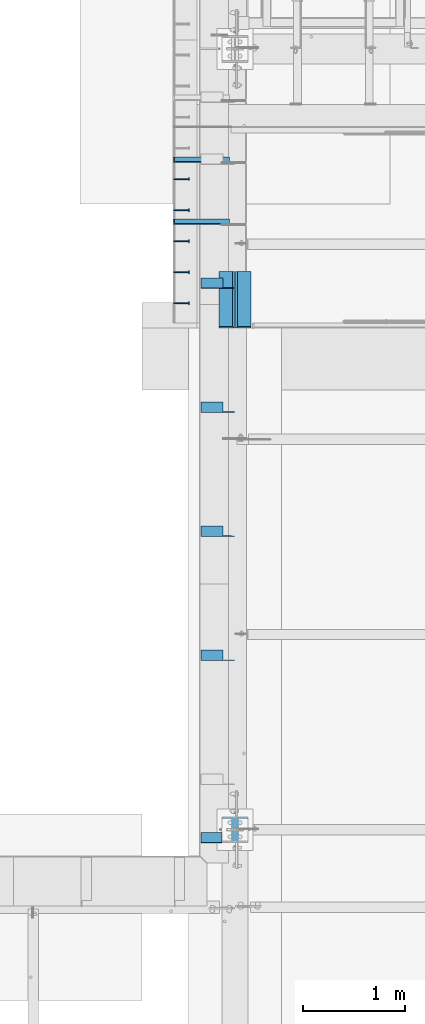
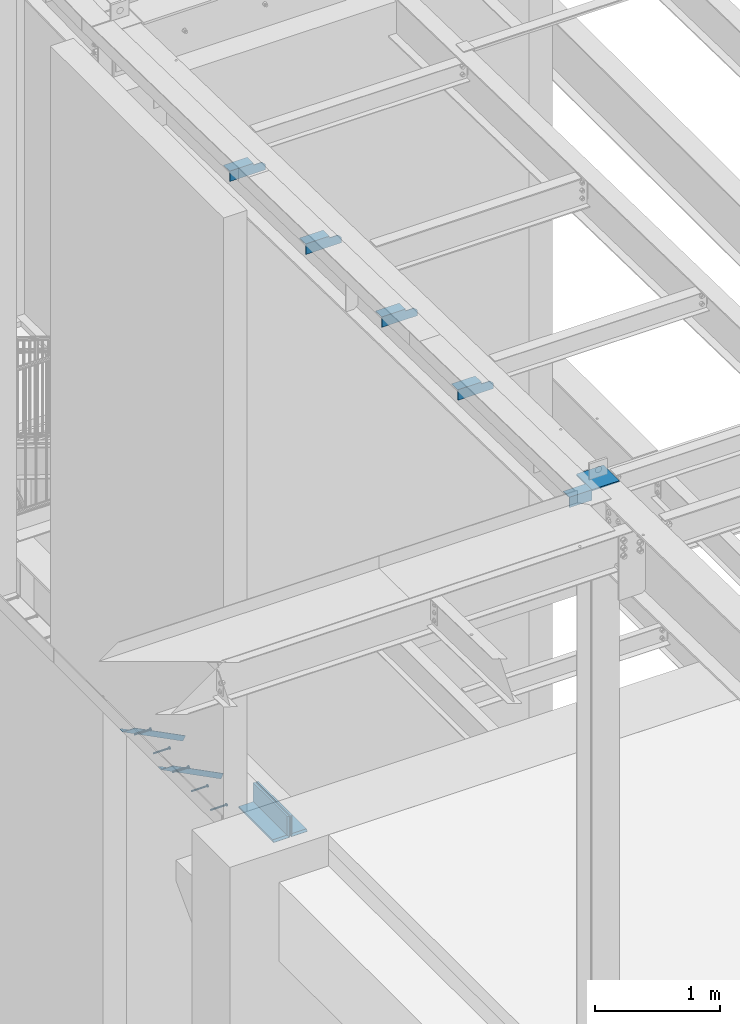
# One storey, part 1248 of 1763: 13 beams, 2 members, 10 elements without a shape of their own.
"""IFC2X3 building model written with IfcOpenShell, lengths in millimetres."""

import ifcopenshell
import ifcopenshell.guid

model = None  # the IFC model being written
_history = None  # IfcOwnerHistory: only IFC2X3 demands one
_inside = {}  # id of a spatial element -> (the spatial element, [elements in it])
_under = {}  # id of a project, library or spatial element -> (it, [spatial elements below it])
_declared = {}  # id of a project -> (the project, [libraries it declares])
_typed = {}  # id of a type object -> (the type object, [elements of that type])
_made_of = {}  # id of a material, layer set ... -> (it, [elements and type objects made of it])


def new_model(schema):
    """Start an empty IFC model of exactly this schema.

    Asked for "IFC4X3", IfcOpenShell would pick the latest addendum, in which some entities
    have other attributes; the version numbers below select the first issue.
    IFC2X3 requires an IfcOwnerHistory on every rooted entity: one is made here for all.
    """
    global model, _history
    if schema == "IFC4X3":
        model = ifcopenshell.file(schema_version=(4, 3, 0, 0))
    else:
        model = ifcopenshell.file(schema=schema)
    _inside.clear()
    _under.clear()
    _declared.clear()
    _typed.clear()
    _made_of.clear()
    _history = None
    if model.schema == "IFC2X3":
        org = make("IfcOrganization", Name="unknown")
        user = make(
            "IfcPersonAndOrganization",
            ThePerson=make("IfcPerson", FamilyName="unknown"),
            TheOrganization=org,
        )
        app = make(
            "IfcApplication",
            ApplicationDeveloper=org,
            Version="unknown",
            ApplicationFullName="unknown",
            ApplicationIdentifier="unknown",
        )
        _history = make(
            "IfcOwnerHistory",
            OwningUser=user,
            OwningApplication=app,
            ChangeAction="ADDED",
            CreationDate=0,
        )
    return model


def make(cls, **values):
    """One entity of the class cls with the attributes given. An attribute that is None is left unset."""
    return model.create_entity(
        cls, **{name: value for name, value in values.items() if value is not None}
    )


def rooted(cls, **values):
    """An entity with a GlobalId (a new one), such as an element, a storey or a relation."""
    return make(cls, GlobalId=ifcopenshell.guid.new(), OwnerHistory=_history, **values)


def si_unit(unit_type, name, prefix=None):
    """IfcSIUnit, for example si_unit("LENGTHUNIT", "METRE", prefix="MILLI")."""
    return make("IfcSIUnit", UnitType=unit_type, Prefix=prefix, Name=name)


def assignment(units):
    """IfcUnitAssignment: the units of a project."""
    return None if units is None else make("IfcUnitAssignment", Units=units)


def point(xyz):
    """IfcCartesianPoint."""
    return None if xyz is None else make("IfcCartesianPoint", Coordinates=xyz)


def direction(xyz):
    """IfcDirection."""
    return None if xyz is None else make("IfcDirection", DirectionRatios=xyz)


def frame(location, z_axis=None, x_axis=None):
    """IfcAxis2Placement3D, a coordinate frame: its origin and axes. An axis left out is left unset."""
    return make(
        "IfcAxis2Placement3D",
        Location=point(location),
        Axis=direction(z_axis),
        RefDirection=direction(x_axis),
    )


def origin_with_axes():
    """The frame at (0, 0, 0) with the z axis (0, 0, 1) and the x axis (1, 0, 0) written out."""
    return frame((0.0, 0.0, 0.0), z_axis=(0.0, 0.0, 1.0), x_axis=(1.0, 0.0, 0.0))


def place(relative_to, where):
    """IfcLocalPlacement: puts the frame where relative to a parent placement (None: the world)."""
    return make(
        "IfcLocalPlacement", PlacementRelTo=relative_to, RelativePlacement=where
    )


def context(
    kind, dimensions, precision=None, world=None, true_north=None, identifier=None
):
    """IfcGeometricRepresentationContext, for example the 3D "Model" context."""
    return make(
        "IfcGeometricRepresentationContext",
        ContextIdentifier=identifier,
        ContextType=kind,
        CoordinateSpaceDimension=dimensions,
        Precision=precision,
        WorldCoordinateSystem=world,
        TrueNorth=true_north,
    )


def subcontext(parent, identifier, kind, view, scale=None):
    """IfcGeometricRepresentationSubContext, for example "Body" below "Model"."""
    return make(
        "IfcGeometricRepresentationSubContext",
        ContextIdentifier=identifier,
        ContextType=kind,
        ParentContext=parent,
        TargetScale=scale,
        TargetView=view,
    )


def project(units=None, contexts=None):
    """IfcProject with its units and contexts."""
    return rooted(
        "IfcProject",
        Name="project",
        RepresentationContexts=contexts,
        UnitsInContext=assignment(units),
    )


def spatial(cls, under=None, at=None, **own):
    """A site, building, storey or space (cls), placed at a placement, below another one or the project."""
    s = rooted(cls, ObjectPlacement=at, **own)
    if under is not None:
        _under.setdefault(under.id(), (under, []))[1].append(s)
    return s


def faces_of(points, faces, orient=None, outer=None):
    """IfcFace entities. A face is a list of loops; a loop is a list of indices into points, from 0.

    orient and outer hold one flag for each loop. By default every Orientation is true, the
    first loop of a face is its IfcFaceOuterBound and the others are IfcFaceBound.
    """
    made = []
    for i, loops in enumerate(faces):
        bounds = []
        for j, loop in enumerate(loops):
            is_outer = j == 0 if outer is None else outer[i][j]
            bounds.append(
                make(
                    "IfcFaceOuterBound" if is_outer else "IfcFaceBound",
                    Bound=make("IfcPolyLoop", Polygon=[points[k] for k in loop]),
                    Orientation=True if orient is None else orient[i][j],
                )
            )
        made.append(make("IfcFace", Bounds=bounds))
    return made


def faceted_brep(points, faces, orient=None, outer=None, voids=None):
    """IfcFacetedBrep: a solid bounded by flat faces; with voids (closed shells), ...WithVoids."""
    shared = [point(p) for p in points]
    hull = make("IfcClosedShell", CfsFaces=faces_of(shared, faces, orient, outer))
    if voids is None:
        return make("IfcFacetedBrep", Outer=hull)
    return make(
        "IfcFacetedBrepWithVoids",
        Outer=hull,
        Voids=[
            make(cls, CfsFaces=faces_of(shared, fs, o, b)) for cls, fs, o, b in voids
        ],
    )


def shape(context_of_items, identifier, shape_type, items):
    """IfcShapeRepresentation: the items that make up one representation, for example the "Body"."""
    return make(
        "IfcShapeRepresentation",
        ContextOfItems=context_of_items,
        RepresentationIdentifier=identifier,
        RepresentationType=shape_type,
        Items=items,
    )


def material(Name=None, Category=None):
    """IfcMaterial."""
    return make("IfcMaterial", Name=Name, Category=Category)


def made_of(thing, what):
    """Note that an element or type object is made of a material, layer set ...; save() writes the relation."""
    if what is not None:
        _made_of.setdefault(what.id(), (what, []))[1].append(thing)
    return thing


def type_object(cls, material=None, **own):
    """A type object (cls), such as IfcWallType, which elements share."""
    return made_of(rooted(cls, **own), material)


def element(
    cls,
    number,
    at=None,
    inside=None,
    cuts=None,
    type_object=None,
    material=None,
    context=None,
    identifier="Body",
    shape_type=None,
    held_by="IfcProductDefinitionShape",
    body=None,
    shapes=None,
    **own,
):
    """One element of the class cls, such as IfcWall. Its Tag is "e" and its number.

    at: its placement. inside: the storey or other place that contains it. cuts: it is an
    opening in that element (IfcRelVoidsElement). A single representation is given by context,
    identifier, shape_type and body (its items); several are given by shapes. held_by: the class
    of the entity that holds the representations. save() writes the other relations.
    """
    e = rooted(cls, Tag="e%d" % number, ObjectPlacement=at, **own)
    if body is not None:
        shapes = [shape(context, identifier, shape_type, body)]
    if shapes is not None:
        e.Representation = make(held_by, Representations=shapes)
    if inside is not None:
        _inside.setdefault(inside.id(), (inside, []))[1].append(e)
    if cuts is not None:
        rooted(
            "IfcRelVoidsElement", RelatingBuildingElement=cuts, RelatedOpeningElement=e
        )
    if type_object is not None:
        _typed.setdefault(type_object.id(), (type_object, []))[1].append(e)
    return made_of(e, material)


def aggregate(whole, parts):
    """IfcRelAggregates: a whole, such as a stair, and the parts it consists of."""
    return rooted("IfcRelAggregates", RelatingObject=whole, RelatedObjects=parts)


def save(model, path):
    """Write the relations noted so far, then the file.

    IfcRelAggregates (storeys below a building ...), IfcRelContainedInSpatialStructure (elements
    in a storey), IfcRelDefinesByType, IfcRelAssociatesMaterial and IfcRelDeclares: one each for
    every whole, place, type object, material and project.
    """
    for whole, parts in _under.values():
        aggregate(whole, parts)
    for where, things in _inside.values():
        rooted(
            "IfcRelContainedInSpatialStructure",
            RelatedElements=things,
            RelatingStructure=where,
        )
    for kind, things in _typed.values():
        rooted("IfcRelDefinesByType", RelatedObjects=things, RelatingType=kind)
    for what, things in _made_of.values():
        rooted("IfcRelAssociatesMaterial", RelatedObjects=things, RelatingMaterial=what)
    for by, libraries in _declared.values():
        rooted("IfcRelDeclares", RelatingContext=by, RelatedDefinitions=libraries)
    model.write(path)


model = new_model("IFC2X3")

# Units and contexts
model_context = context("Model", 3, precision=1e-05, world=origin_with_axes())
body_context = subcontext(model_context, "Body", "Model", "MODEL_VIEW")
ifc_project = project(units=[si_unit("LENGTHUNIT", "METRE", prefix="MILLI"), si_unit("AREAUNIT", "SQUARE_METRE"), si_unit("VOLUMEUNIT", "CUBIC_METRE"), si_unit("MASSUNIT", "GRAM", prefix="KILO"), si_unit("TIMEUNIT", "SECOND"), si_unit("PLANEANGLEUNIT", "RADIAN"), si_unit("SOLIDANGLEUNIT", "STERADIAN"), si_unit("THERMODYNAMICTEMPERATUREUNIT", "DEGREE_CELSIUS"), si_unit("LUMINOUSINTENSITYUNIT", "LUMEN")], contexts=[model_context])

# Site, building, storey
site_placement = place(None, origin_with_axes())
site = spatial("IfcSite", under=ifc_project, at=site_placement, CompositionType="ELEMENT")
building_placement = place(site_placement, origin_with_axes())
building = spatial("IfcBuilding", under=site, at=building_placement, Name="Undefined", CompositionType="ELEMENT")
storey_placement = place(building_placement, origin_with_axes())
storey = spatial("IfcBuildingStorey", under=building, at=storey_placement, Name="Undefined", CompositionType="ELEMENT", Elevation=0.0)

# Assembly, beam
assembly_1_placement = place(storey_placement, origin_with_axes())
assembly_1 = element("IfcElementAssembly", 1, at=assembly_1_placement, inside=storey, Name="HEADED STUD ANCHOR", AssemblyPlace="NOTDEFINED", PredefinedType="RIGID_FRAME")
ifc_material_1 = material(Name="STEEL/A108")
beam_type_1 = type_object("IfcBeamType", PredefinedType="NOTDEFINED")
beam_1_placement = place(assembly_1_placement, frame((-87975.5122736983, 27524.0750061035, 5268.91250001202), z_axis=(0.0, 0.0, -1.0), x_axis=(1.0, 0.0, 0.0)))
beam_1 = element("IfcBeam", 2, at=beam_1_placement, type_object=beam_type_1, material=ifc_material_1, Name="HEADED STUD ANCHOR", context=body_context, shape_type="Brep", body=[
    faceted_brep([(0.0, -3.1800000667572, 5.5), (0.0, -5.5, 3.1800000667572), (141.732000000002, -5.5, 3.1800000667572), (141.732000000002, -3.1800000667572, 5.5), (0.0, -6.34999999999491, 1.45519152283669e-11), (141.732000000002, -6.34999990463257, 0.0), (0.0, -5.5, -3.1800000667572), (141.732000000002, -5.5, -3.1800000667572), (0.0, -3.1800000667572, -5.5), (141.732000000002, -3.1800000667572, -5.5), (0.0, 0.0, -6.34999990463257), (141.732000000002, 0.0, -6.34999990463257), (0.0, 3.1800000667572, -5.5), (141.732000000002, 3.1800000667572, -5.5), (0.0, 5.5, -3.1800000667572), (141.732000000002, 5.5, -3.1800000667572), (0.0, 6.34999999999491, -2.91038304567337e-11), (141.732000000002, 6.34999990463257, 0.0), (0.0, 5.5, 3.1800000667572), (141.732000000002, 5.5, 3.1800000667572), (0.0, 3.1800000667572, 5.5), (141.732000000002, 3.1800000667572, 5.5), (0.0, 0.0, 6.34999990463257), (141.732000000002, 0.0, 6.34999990463257), (144.780000000001, -10.9899997711182, 6.34999990463257), (144.780000000001, -6.34000015258789, 10.9899997711182), (144.780000000001, -12.6999998092651, 0.0), (144.780000000001, -10.9899997711182, -6.34999990463257), (144.780000000001, -6.34000015258789, -10.9899997711182), (144.780000000001, 0.0, -12.6899995803833), (144.780000000001, 6.34000015258789, -10.9899997711182), (144.780000000001, 10.9899997711182, -6.34999990463257), (144.780000000001, 12.6999998092651, 0.0), (144.780000000001, 10.9899997711182, 6.34999990463257), (144.780000000001, 6.34000015258789, 10.9899997711182), (144.780000000001, 0.0, 12.6899995803833), (152.400000000001, -10.9899997711182, 6.34999990463257), (152.400000000001, -6.34000015258789, 10.9899997711182), (152.400000000001, -12.6999998092651, 0.0), (152.400000000001, -10.9899997711182, -6.34999990463257), (152.400000000001, -6.34000015258789, -10.9899997711182), (152.400000000001, 0.0, -12.6899995803833), (152.400000000001, 6.34000015258789, -10.9899997711182), (152.400000000001, 10.9899997711182, -6.34999990463257), (152.400000000001, 12.6999998092651, 0.0), (152.400000000001, 10.9899997711182, 6.34999990463257), (152.400000000001, 6.34000015258789, 10.9899997711182), (152.400000000001, 0.0, 12.6899995803833)], [[[0, 1, 2, 3]], [[1, 4, 5, 2]], [[4, 6, 7, 5]], [[6, 8, 9, 7]], [[8, 10, 11, 9]], [[10, 12, 13, 11]], [[12, 14, 15, 13]], [[14, 16, 17, 15]], [[16, 18, 19, 17]], [[18, 20, 21, 19]], [[20, 22, 23, 21]], [[22, 0, 3, 23]], [[22, 20, 18, 16, 14, 12, 10, 8, 6, 4, 1, 0]], [[3, 2, 24, 25]], [[2, 5, 26, 24]], [[5, 7, 27, 26]], [[7, 9, 28, 27]], [[9, 11, 29, 28]], [[11, 13, 30, 29]], [[13, 15, 31, 30]], [[15, 17, 32, 31]], [[17, 19, 33, 32]], [[19, 21, 34, 33]], [[21, 23, 35, 34]], [[23, 3, 25, 35]], [[25, 24, 36, 37]], [[24, 26, 38, 36]], [[26, 27, 39, 38]], [[27, 28, 40, 39]], [[28, 29, 41, 40]], [[29, 30, 42, 41]], [[30, 31, 43, 42]], [[31, 32, 44, 43]], [[32, 33, 45, 44]], [[33, 34, 46, 45]], [[34, 35, 47, 46]], [[35, 25, 37, 47]], [[38, 39, 40, 41, 42, 43, 44, 45, 46, 47, 37, 36]]]),
])
aggregate(assembly_1, [beam_1])

assembly_2_placement = place(storey_placement, origin_with_axes())
assembly_2 = element("IfcElementAssembly", 3, at=assembly_2_placement, inside=storey, Name="HEADED STUD ANCHOR", AssemblyPlace="NOTDEFINED", PredefinedType="RIGID_FRAME")
beam_2_placement = place(assembly_2_placement, frame((-87975.5122736983, 27828.8750061035, 5268.91250001202), z_axis=(0.0, 0.0, -1.0), x_axis=(1.0, 0.0, 0.0)))
beam_2 = element("IfcBeam", 4, at=beam_2_placement, type_object=beam_type_1, material=ifc_material_1, Name="HEADED STUD ANCHOR", context=body_context, shape_type="Brep", body=[
    faceted_brep([(0.0, -3.1800000667572, 5.5), (0.0, -5.5, 3.1800000667572), (141.732000000002, -5.5, 3.1800000667572), (141.732000000002, -3.1800000667572, 5.5), (0.0, -6.34999999999491, 1.45519152283669e-11), (141.732000000002, -6.34999990463257, 0.0), (0.0, -5.5, -3.1800000667572), (141.732000000002, -5.5, -3.1800000667572), (0.0, -3.1800000667572, -5.5), (141.732000000002, -3.1800000667572, -5.5), (0.0, 0.0, -6.34999990463257), (141.732000000002, 0.0, -6.34999990463257), (0.0, 3.1800000667572, -5.5), (141.732000000002, 3.1800000667572, -5.5), (0.0, 5.5, -3.1800000667572), (141.732000000002, 5.5, -3.1800000667572), (0.0, 6.34999999999491, -2.91038304567337e-11), (141.732000000002, 6.34999990463257, 0.0), (0.0, 5.5, 3.1800000667572), (141.732000000002, 5.5, 3.1800000667572), (0.0, 3.1800000667572, 5.5), (141.732000000002, 3.1800000667572, 5.5), (0.0, 0.0, 6.34999990463257), (141.732000000002, 0.0, 6.34999990463257), (144.780000000001, -10.9899997711182, 6.34999990463257), (144.780000000001, -6.34000015258789, 10.9899997711182), (144.780000000001, -12.6999998092651, 0.0), (144.780000000001, -10.9899997711182, -6.34999990463257), (144.780000000001, -6.34000015258789, -10.9899997711182), (144.780000000001, 0.0, -12.6899995803833), (144.780000000001, 6.34000015258789, -10.9899997711182), (144.780000000001, 10.9899997711182, -6.34999990463257), (144.780000000001, 12.6999998092651, 0.0), (144.780000000001, 10.9899997711182, 6.34999990463257), (144.780000000001, 6.34000015258789, 10.9899997711182), (144.780000000001, 0.0, 12.6899995803833), (152.400000000001, -10.9899997711182, 6.34999990463257), (152.400000000001, -6.34000015258789, 10.9899997711182), (152.400000000001, -12.6999998092651, 0.0), (152.400000000001, -10.9899997711182, -6.34999990463257), (152.400000000001, -6.34000015258789, -10.9899997711182), (152.400000000001, 0.0, -12.6899995803833), (152.400000000001, 6.34000015258789, -10.9899997711182), (152.400000000001, 10.9899997711182, -6.34999990463257), (152.400000000001, 12.6999998092651, 0.0), (152.400000000001, 10.9899997711182, 6.34999990463257), (152.400000000001, 6.34000015258789, 10.9899997711182), (152.400000000001, 0.0, 12.6899995803833)], [[[0, 1, 2, 3]], [[1, 4, 5, 2]], [[4, 6, 7, 5]], [[6, 8, 9, 7]], [[8, 10, 11, 9]], [[10, 12, 13, 11]], [[12, 14, 15, 13]], [[14, 16, 17, 15]], [[16, 18, 19, 17]], [[18, 20, 21, 19]], [[20, 22, 23, 21]], [[22, 0, 3, 23]], [[22, 20, 18, 16, 14, 12, 10, 8, 6, 4, 1, 0]], [[3, 2, 24, 25]], [[2, 5, 26, 24]], [[5, 7, 27, 26]], [[7, 9, 28, 27]], [[9, 11, 29, 28]], [[11, 13, 30, 29]], [[13, 15, 31, 30]], [[15, 17, 32, 31]], [[17, 19, 33, 32]], [[19, 21, 34, 33]], [[21, 23, 35, 34]], [[23, 3, 25, 35]], [[25, 24, 36, 37]], [[24, 26, 38, 36]], [[26, 27, 39, 38]], [[27, 28, 40, 39]], [[28, 29, 41, 40]], [[29, 30, 42, 41]], [[30, 31, 43, 42]], [[31, 32, 44, 43]], [[32, 33, 45, 44]], [[33, 34, 46, 45]], [[34, 35, 47, 46]], [[35, 25, 37, 47]], [[38, 39, 40, 41, 42, 43, 44, 45, 46, 47, 37, 36]]]),
])
aggregate(assembly_2, [beam_2])

assembly_3_placement = place(storey_placement, origin_with_axes())
assembly_3 = element("IfcElementAssembly", 5, at=assembly_3_placement, inside=storey, Name="HEADED STUD ANCHOR", AssemblyPlace="NOTDEFINED", PredefinedType="RIGID_FRAME")
beam_3_placement = place(assembly_3_placement, frame((-87975.5122736983, 28133.6750061035, 5268.91250001202), z_axis=(0.0, 0.0, -1.0), x_axis=(1.0, 0.0, 0.0)))
beam_3 = element("IfcBeam", 6, at=beam_3_placement, type_object=beam_type_1, material=ifc_material_1, Name="HEADED STUD ANCHOR", context=body_context, shape_type="Brep", body=[
    faceted_brep([(0.0, -3.1800000667572, 5.5), (0.0, -5.5, 3.1800000667572), (141.732000000002, -5.5, 3.1800000667572), (141.732000000002, -3.1800000667572, 5.5), (0.0, -6.34999999999491, 1.45519152283669e-11), (141.732000000002, -6.34999990463257, 0.0), (0.0, -5.5, -3.1800000667572), (141.732000000002, -5.5, -3.1800000667572), (0.0, -3.1800000667572, -5.5), (141.732000000002, -3.1800000667572, -5.5), (0.0, 0.0, -6.34999990463257), (141.732000000002, 0.0, -6.34999990463257), (0.0, 3.1800000667572, -5.5), (141.732000000002, 3.1800000667572, -5.5), (0.0, 5.5, -3.1800000667572), (141.732000000002, 5.5, -3.1800000667572), (0.0, 6.34999999999491, -2.91038304567337e-11), (141.732000000002, 6.34999990463257, 0.0), (0.0, 5.5, 3.1800000667572), (141.732000000002, 5.5, 3.1800000667572), (0.0, 3.1800000667572, 5.5), (141.732000000002, 3.1800000667572, 5.5), (0.0, 0.0, 6.34999990463257), (141.732000000002, 0.0, 6.34999990463257), (144.780000000001, -10.9899997711182, 6.34999990463257), (144.780000000001, -6.34000015258789, 10.9899997711182), (144.780000000001, -12.6999998092651, 0.0), (144.780000000001, -10.9899997711182, -6.34999990463257), (144.780000000001, -6.34000015258789, -10.9899997711182), (144.780000000001, 0.0, -12.6899995803833), (144.780000000001, 6.34000015258789, -10.9899997711182), (144.780000000001, 10.9899997711182, -6.34999990463257), (144.780000000001, 12.6999998092651, 0.0), (144.780000000001, 10.9899997711182, 6.34999990463257), (144.780000000001, 6.34000015258789, 10.9899997711182), (144.780000000001, 0.0, 12.6899995803833), (152.400000000001, -10.9899997711182, 6.34999990463257), (152.400000000001, -6.34000015258789, 10.9899997711182), (152.400000000001, -12.6999998092651, 0.0), (152.400000000001, -10.9899997711182, -6.34999990463257), (152.400000000001, -6.34000015258789, -10.9899997711182), (152.400000000001, 0.0, -12.6899995803833), (152.400000000001, 6.34000015258789, -10.9899997711182), (152.400000000001, 10.9899997711182, -6.34999990463257), (152.400000000001, 12.6999998092651, 0.0), (152.400000000001, 10.9899997711182, 6.34999990463257), (152.400000000001, 6.34000015258789, 10.9899997711182), (152.400000000001, 0.0, 12.6899995803833)], [[[0, 1, 2, 3]], [[1, 4, 5, 2]], [[4, 6, 7, 5]], [[6, 8, 9, 7]], [[8, 10, 11, 9]], [[10, 12, 13, 11]], [[12, 14, 15, 13]], [[14, 16, 17, 15]], [[16, 18, 19, 17]], [[18, 20, 21, 19]], [[20, 22, 23, 21]], [[22, 0, 3, 23]], [[22, 20, 18, 16, 14, 12, 10, 8, 6, 4, 1, 0]], [[3, 2, 24, 25]], [[2, 5, 26, 24]], [[5, 7, 27, 26]], [[7, 9, 28, 27]], [[9, 11, 29, 28]], [[11, 13, 30, 29]], [[13, 15, 31, 30]], [[15, 17, 32, 31]], [[17, 19, 33, 32]], [[19, 21, 34, 33]], [[21, 23, 35, 34]], [[23, 3, 25, 35]], [[25, 24, 36, 37]], [[24, 26, 38, 36]], [[26, 27, 39, 38]], [[27, 28, 40, 39]], [[28, 29, 41, 40]], [[29, 30, 42, 41]], [[30, 31, 43, 42]], [[31, 32, 44, 43]], [[32, 33, 45, 44]], [[33, 34, 46, 45]], [[34, 35, 47, 46]], [[35, 25, 37, 47]], [[38, 39, 40, 41, 42, 43, 44, 45, 46, 47, 37, 36]]]),
])
aggregate(assembly_3, [beam_3])

assembly_4_placement = place(storey_placement, origin_with_axes())
assembly_4 = element("IfcElementAssembly", 7, at=assembly_4_placement, inside=storey, Name="HEADED STUD ANCHOR", AssemblyPlace="NOTDEFINED", PredefinedType="RIGID_FRAME")
beam_4_placement = place(assembly_4_placement, frame((-87975.5122736983, 28438.4750061035, 5268.91250001202), z_axis=(0.0, 0.0, -1.0), x_axis=(1.0, 0.0, 0.0)))
beam_4 = element("IfcBeam", 8, at=beam_4_placement, type_object=beam_type_1, material=ifc_material_1, Name="HEADED STUD ANCHOR", context=body_context, shape_type="Brep", body=[
    faceted_brep([(0.0, -3.1800000667572, 5.5), (0.0, -5.5, 3.1800000667572), (141.732000000002, -5.5, 3.1800000667572), (141.732000000002, -3.1800000667572, 5.5), (0.0, -6.34999999999491, 1.45519152283669e-11), (141.732000000002, -6.34999990463257, 0.0), (0.0, -5.5, -3.1800000667572), (141.732000000002, -5.5, -3.1800000667572), (0.0, -3.1800000667572, -5.5), (141.732000000002, -3.1800000667572, -5.5), (0.0, 0.0, -6.34999990463257), (141.732000000002, 0.0, -6.34999990463257), (0.0, 3.1800000667572, -5.5), (141.732000000002, 3.1800000667572, -5.5), (0.0, 5.5, -3.1800000667572), (141.732000000002, 5.5, -3.1800000667572), (0.0, 6.34999999999491, -2.91038304567337e-11), (141.732000000002, 6.34999990463257, 0.0), (0.0, 5.5, 3.1800000667572), (141.732000000002, 5.5, 3.1800000667572), (0.0, 3.1800000667572, 5.5), (141.732000000002, 3.1800000667572, 5.5), (0.0, 0.0, 6.34999990463257), (141.732000000002, 0.0, 6.34999990463257), (144.780000000001, -10.9899997711182, 6.34999990463257), (144.780000000001, -6.34000015258789, 10.9899997711182), (144.780000000001, -12.6999998092651, 0.0), (144.780000000001, -10.9899997711182, -6.34999990463257), (144.780000000001, -6.34000015258789, -10.9899997711182), (144.780000000001, 0.0, -12.6899995803833), (144.780000000001, 6.34000015258789, -10.9899997711182), (144.780000000001, 10.9899997711182, -6.34999990463257), (144.780000000001, 12.6999998092651, 0.0), (144.780000000001, 10.9899997711182, 6.34999990463257), (144.780000000001, 6.34000015258789, 10.9899997711182), (144.780000000001, 0.0, 12.6899995803833), (152.400000000001, -10.9899997711182, 6.34999990463257), (152.400000000001, -6.34000015258789, 10.9899997711182), (152.400000000001, -12.6999998092651, 0.0), (152.400000000001, -10.9899997711182, -6.34999990463257), (152.400000000001, -6.34000015258789, -10.9899997711182), (152.400000000001, 0.0, -12.6899995803833), (152.400000000001, 6.34000015258789, -10.9899997711182), (152.400000000001, 10.9899997711182, -6.34999990463257), (152.400000000001, 12.6999998092651, 0.0), (152.400000000001, 10.9899997711182, 6.34999990463257), (152.400000000001, 6.34000015258789, 10.9899997711182), (152.400000000001, 0.0, 12.6899995803833)], [[[0, 1, 2, 3]], [[1, 4, 5, 2]], [[4, 6, 7, 5]], [[6, 8, 9, 7]], [[8, 10, 11, 9]], [[10, 12, 13, 11]], [[12, 14, 15, 13]], [[14, 16, 17, 15]], [[16, 18, 19, 17]], [[18, 20, 21, 19]], [[20, 22, 23, 21]], [[22, 0, 3, 23]], [[22, 20, 18, 16, 14, 12, 10, 8, 6, 4, 1, 0]], [[3, 2, 24, 25]], [[2, 5, 26, 24]], [[5, 7, 27, 26]], [[7, 9, 28, 27]], [[9, 11, 29, 28]], [[11, 13, 30, 29]], [[13, 15, 31, 30]], [[15, 17, 32, 31]], [[17, 19, 33, 32]], [[19, 21, 34, 33]], [[21, 23, 35, 34]], [[23, 3, 25, 35]], [[25, 24, 36, 37]], [[24, 26, 38, 36]], [[26, 27, 39, 38]], [[27, 28, 40, 39]], [[28, 29, 41, 40]], [[29, 30, 42, 41]], [[30, 31, 43, 42]], [[31, 32, 44, 43]], [[32, 33, 45, 44]], [[33, 34, 46, 45]], [[34, 35, 47, 46]], [[35, 25, 37, 47]], [[38, 39, 40, 41, 42, 43, 44, 45, 46, 47, 37, 36]]]),
])
aggregate(assembly_4, [beam_4])

assembly_5_placement = place(storey_placement, origin_with_axes())
assembly_5 = element("IfcElementAssembly", 9, at=assembly_5_placement, inside=storey, Name="HEADED STUD ANCHOR", AssemblyPlace="NOTDEFINED", PredefinedType="RIGID_FRAME")
beam_5_placement = place(assembly_5_placement, frame((-87975.5122736983, 28743.2750061035, 5268.91250001202), z_axis=(0.0, 0.0, -1.0), x_axis=(1.0, 0.0, 0.0)))
beam_5 = element("IfcBeam", 10, at=beam_5_placement, type_object=beam_type_1, material=ifc_material_1, Name="HEADED STUD ANCHOR", context=body_context, shape_type="Brep", body=[
    faceted_brep([(0.0, -3.1800000667572, 5.5), (0.0, -5.5, 3.1800000667572), (141.732000000002, -5.5, 3.1800000667572), (141.732000000002, -3.1800000667572, 5.5), (0.0, -6.34999999999491, 1.45519152283669e-11), (141.732000000002, -6.34999990463257, 0.0), (0.0, -5.5, -3.1800000667572), (141.732000000002, -5.5, -3.1800000667572), (0.0, -3.1800000667572, -5.5), (141.732000000002, -3.1800000667572, -5.5), (0.0, 0.0, -6.34999990463257), (141.732000000002, 0.0, -6.34999990463257), (0.0, 3.1800000667572, -5.5), (141.732000000002, 3.1800000667572, -5.5), (0.0, 5.5, -3.1800000667572), (141.732000000002, 5.5, -3.1800000667572), (0.0, 6.34999999999491, -2.91038304567337e-11), (141.732000000002, 6.34999990463257, 0.0), (0.0, 5.5, 3.1800000667572), (141.732000000002, 5.5, 3.1800000667572), (0.0, 3.1800000667572, 5.5), (141.732000000002, 3.1800000667572, 5.5), (0.0, 0.0, 6.34999990463257), (141.732000000002, 0.0, 6.34999990463257), (144.780000000001, -10.9899997711182, 6.34999990463257), (144.780000000001, -6.34000015258789, 10.9899997711182), (144.780000000001, -12.6999998092651, 0.0), (144.780000000001, -10.9899997711182, -6.34999990463257), (144.780000000001, -6.34000015258789, -10.9899997711182), (144.780000000001, 0.0, -12.6899995803833), (144.780000000001, 6.34000015258789, -10.9899997711182), (144.780000000001, 10.9899997711182, -6.34999990463257), (144.780000000001, 12.6999998092651, 0.0), (144.780000000001, 10.9899997711182, 6.34999990463257), (144.780000000001, 6.34000015258789, 10.9899997711182), (144.780000000001, 0.0, 12.6899995803833), (152.400000000001, -10.9899997711182, 6.34999990463257), (152.400000000001, -6.34000015258789, 10.9899997711182), (152.400000000001, -12.6999998092651, 0.0), (152.400000000001, -10.9899997711182, -6.34999990463257), (152.400000000001, -6.34000015258789, -10.9899997711182), (152.400000000001, 0.0, -12.6899995803833), (152.400000000001, 6.34000015258789, -10.9899997711182), (152.400000000001, 10.9899997711182, -6.34999990463257), (152.400000000001, 12.6999998092651, 0.0), (152.400000000001, 10.9899997711182, 6.34999990463257), (152.400000000001, 6.34000015258789, 10.9899997711182), (152.400000000001, 0.0, 12.6899995803833)], [[[0, 1, 2, 3]], [[1, 4, 5, 2]], [[4, 6, 7, 5]], [[6, 8, 9, 7]], [[8, 10, 11, 9]], [[10, 12, 13, 11]], [[12, 14, 15, 13]], [[14, 16, 17, 15]], [[16, 18, 19, 17]], [[18, 20, 21, 19]], [[20, 22, 23, 21]], [[22, 0, 3, 23]], [[22, 20, 18, 16, 14, 12, 10, 8, 6, 4, 1, 0]], [[3, 2, 24, 25]], [[2, 5, 26, 24]], [[5, 7, 27, 26]], [[7, 9, 28, 27]], [[9, 11, 29, 28]], [[11, 13, 30, 29]], [[13, 15, 31, 30]], [[15, 17, 32, 31]], [[17, 19, 33, 32]], [[19, 21, 34, 33]], [[21, 23, 35, 34]], [[23, 3, 25, 35]], [[25, 24, 36, 37]], [[24, 26, 38, 36]], [[26, 27, 39, 38]], [[27, 28, 40, 39]], [[28, 29, 41, 40]], [[29, 30, 42, 41]], [[30, 31, 43, 42]], [[31, 32, 44, 43]], [[32, 33, 45, 44]], [[33, 34, 46, 45]], [[34, 35, 47, 46]], [[35, 25, 37, 47]], [[38, 39, 40, 41, 42, 43, 44, 45, 46, 47, 37, 36]]]),
])
aggregate(assembly_5, [beam_5])

# Assembly, members
assembly_6_placement = place(storey_placement, origin_with_axes())
assembly_6 = element("IfcElementAssembly", 11, at=assembly_6_placement, inside=storey, Name="BEAM", AssemblyPlace="NOTDEFINED", PredefinedType="RIGID_FRAME")
ifc_material_2 = material(Name="STEEL/A36")
member_type = type_object("IfcMemberType", Name="L2X2X1/4", PredefinedType="NOTDEFINED")
member_1_placement = place(assembly_6_placement, frame((-87419.034014091, 28934.56875, 4933.91987315707), z_axis=(0.454620561889228, 0.0, 0.890685210782981), x_axis=(-0.89068521078298, 0.0, 0.45462056188923)))
member_1 = element("IfcMember", 12, at=member_1_placement, type_object=member_type, material=ifc_material_2, Name="ANGLE", ObjectType="L2X2X1/4", context=body_context, shape_type="Brep", body=[
    faceted_brep([(-1.45519152283669e-11, 25.4000000000015, -25.3999999999869), (1.45519152283669e-11, 25.4000000000015, 25.3999999999796), (522.978374042039, 25.4000000000015, 25.3999999980806), (622.504906836693, 25.4000000000015, -25.4000000021188), (1.45519152283669e-11, 19.0499999999993, 25.3999999999796), (522.978374042039, 19.0499999999993, 25.3999999980806), (-7.27595761418343e-12, 19.0499999999993, -19.0499999999956), (610.064090237356, 19.0499999999993, -19.0500000020984), (-7.27595761418343e-12, -25.4000000000015, -19.0499999999956), (610.064090237356, -25.4000000000015, -19.0500000020984), (-1.45519152283669e-11, -25.4000000000015, -25.3999999999869), (622.504906836693, -25.4000000000015, -25.4000000021188)], [[[0, 1, 2, 3]], [[1, 4, 5, 2]], [[4, 6, 7, 5]], [[6, 8, 9, 7]], [[8, 10, 11, 9]], [[10, 0, 3, 11]], [[5, 7, 9, 11, 3, 2]], [[10, 8, 6, 4, 1, 0]]]),
])
member_2_placement = place(assembly_6_placement, frame((-87419.034014091, 28324.96875, 4933.91987315707), z_axis=(0.454620561889228, 0.0, 0.890685210782981), x_axis=(-0.89068521078298, 0.0, 0.45462056188923)))
member_2 = element("IfcMember", 13, at=member_2_placement, type_object=member_type, material=ifc_material_2, Name="ANGLE", ObjectType="L2X2X1/4", context=body_context, shape_type="Brep", body=[
    faceted_brep([(-1.45519152283669e-11, 25.4000000000015, -25.3999999999869), (1.45519152283669e-11, 25.4000000000015, 25.3999999999796), (522.978374042039, 25.4000000000015, 25.3999999980806), (622.504906836693, 25.4000000000015, -25.4000000021188), (1.45519152283669e-11, 19.0499999999993, 25.3999999999796), (522.978374042039, 19.0499999999993, 25.3999999980806), (-7.27595761418343e-12, 19.0499999999993, -19.0499999999956), (610.064090237356, 19.0499999999993, -19.0500000020984), (-7.27595761418343e-12, -25.4000000000015, -19.0499999999956), (610.064090237356, -25.4000000000015, -19.0500000020984), (-1.45519152283669e-11, -25.4000000000015, -25.3999999999869), (622.504906836693, -25.4000000000015, -25.4000000021188)], [[[0, 1, 2, 3]], [[1, 4, 5, 2]], [[4, 6, 7, 5]], [[6, 8, 9, 7]], [[8, 10, 11, 9]], [[10, 0, 3, 11]], [[5, 7, 9, 11, 3, 2]], [[10, 8, 6, 4, 1, 0]]]),
])
aggregate(assembly_6, [member_1, member_2])

# Assembly, beams
assembly_7_placement = place(storey_placement, origin_with_axes())
assembly_7 = element("IfcElementAssembly", 14, at=assembly_7_placement, inside=storey, Name="BEAM", AssemblyPlace="NOTDEFINED", PredefinedType="RIGID_FRAME")
beam_type_2 = type_object("IfcBeamType", Name="L4X4X1/4", PredefinedType="NOTDEFINED")
beam_6_placement = place(assembly_7_placement, frame((-87711.9872706473, 27721.89073897, 11287.5751778742), z_axis=(0.0, -0.0208942520060009, -0.999781691287208), x_axis=(1.0, 0.0, 0.0)))
beam_6 = element("IfcBeam", 15, at=beam_6_placement, type_object=beam_type_2, material=ifc_material_2, Name="BRACE", ObjectType="L4X4X1/4", context=body_context, shape_type="Brep", body=[
    faceted_brep([(220.662761923406, 44.4500000001208, -44.4499999999807), (220.662761962012, -50.800000000163, -44.4499999999553), (220.66276795695, -50.800000000163, -50.7999999999502), (220.662767915564, 50.8000000001339, -50.7999999999774), (220.662751535681, 50.8000000001339, -33.3786578752915), (220.662751538272, 44.4500000001208, -33.3786578752897), (299.243730570859, 44.4500000001135, -33.3375021376705), (299.243730570859, 50.8000000001339, -33.3375021376723), (2.11002770811319e-10, -50.8000000000357, -50.799999999952), (1.96450855582952e-10, -50.8000000000338, -44.4499999999534), (-2.18278728425503e-11, 44.4500000000007, -44.450000000048), (-1.81898940354586e-10, 44.4500000000371, 50.7999999999374), (-1.96450855582952e-10, 50.8000000000393, 50.7999999999374), (-3.63797880709171e-11, 50.8000000000011, -50.8000000000538), (330.993731689443, 44.4500000000007, 50.7999999999993), (330.993731689443, 50.7999999999993, 50.7999999999993), (330.993730570859, 44.4500000001281, -1.58750213774329), (330.993746948254, 50.8000000001412, -1.5875021377451)], [[[0, 1, 2, 3, 4, 5]], [[6, 5, 4, 7]], [[8, 9, 10, 11, 12, 13]], [[12, 11, 14, 15]], [[15, 14, 16, 17]], [[17, 16, 6, 7]], [[3, 13, 12, 15, 17, 7, 4]], [[8, 13, 3, 2]], [[9, 8, 2, 1]], [[10, 9, 1, 0]], [[16, 14, 11, 10, 0, 5, 6]]]),
])
beam_7_placement = place(assembly_7_placement, frame((-87711.9872706471, 26502.9569009527, 11313.0494499197), z_axis=(0.0, -0.0208942520060009, -0.999781691287208), x_axis=(1.0, 0.0, 0.0)))
beam_7 = element("IfcBeam", 16, at=beam_7_placement, type_object=beam_type_2, material=ifc_material_2, Name="BRACE", ObjectType="L4X4X1/4", context=body_context, shape_type="Brep", body=[
    faceted_brep([(220.662761923406, 44.4500000001208, -44.4499999999807), (220.662761962012, -50.800000000163, -44.4499999999553), (220.66276795695, -50.800000000163, -50.7999999999502), (220.662767915564, 50.8000000001339, -50.7999999999774), (220.662751535681, 50.8000000001339, -33.3786578752915), (220.662751538272, 44.4500000001208, -33.3786578752897), (299.243730570859, 44.4500000001135, -33.3375021376705), (299.243730570859, 50.8000000001339, -33.3375021376723), (2.11002770811319e-10, -50.8000000000357, -50.799999999952), (1.96450855582952e-10, -50.8000000000338, -44.4499999999534), (-2.18278728425503e-11, 44.4500000000007, -44.450000000048), (-1.81898940354586e-10, 44.4500000000371, 50.7999999999374), (-1.96450855582952e-10, 50.8000000000393, 50.7999999999374), (-3.63797880709171e-11, 50.8000000000011, -50.8000000000538), (330.993731689443, 44.4500000000007, 50.7999999999993), (330.993731689443, 50.7999999999993, 50.7999999999993), (330.993730570859, 44.4500000001281, -1.58750213774329), (330.993746948254, 50.8000000001412, -1.5875021377451)], [[[0, 1, 2, 3, 4, 5]], [[6, 5, 4, 7]], [[8, 9, 10, 11, 12, 13]], [[12, 11, 14, 15]], [[15, 14, 16, 17]], [[17, 16, 6, 7]], [[3, 13, 12, 15, 17, 7, 4]], [[8, 13, 3, 2]], [[9, 8, 2, 1]], [[10, 9, 1, 0]], [[16, 14, 11, 10, 0, 5, 6]]]),
])
beam_8_placement = place(assembly_7_placement, frame((-87711.9872706469, 25284.0230629353, 11338.5237219652), z_axis=(0.0, -0.0208942520060009, -0.999781691287208), x_axis=(1.0, 0.0, 0.0)))
beam_8 = element("IfcBeam", 17, at=beam_8_placement, type_object=beam_type_2, material=ifc_material_2, Name="BRACE", ObjectType="L4X4X1/4", context=body_context, shape_type="Brep", body=[
    faceted_brep([(220.662761923406, 44.4500000001208, -44.4499999999807), (220.662761962012, -50.800000000163, -44.4499999999553), (220.66276795695, -50.800000000163, -50.7999999999502), (220.662767915564, 50.8000000001339, -50.7999999999774), (220.662751535681, 50.8000000001339, -33.3786578752915), (220.662751538272, 44.4500000001208, -33.3786578752897), (299.243730570859, 44.4500000001135, -33.3375021376705), (299.243730570859, 50.8000000001339, -33.3375021376723), (2.11002770811319e-10, -50.8000000000357, -50.799999999952), (1.96450855582952e-10, -50.8000000000338, -44.4499999999534), (-2.18278728425503e-11, 44.4500000000007, -44.450000000048), (-1.81898940354586e-10, 44.4500000000371, 50.7999999999374), (-1.96450855582952e-10, 50.8000000000393, 50.7999999999374), (-3.63797880709171e-11, 50.8000000000011, -50.8000000000538), (330.993731689443, 44.4500000000007, 50.7999999999993), (330.993731689443, 50.7999999999993, 50.7999999999993), (330.993730570859, 44.4500000001281, -1.58750213774329), (330.993746948254, 50.8000000001412, -1.5875021377451)], [[[0, 1, 2, 3, 4, 5]], [[6, 5, 4, 7]], [[8, 9, 10, 11, 12, 13]], [[12, 11, 14, 15]], [[15, 14, 16, 17]], [[17, 16, 6, 7]], [[3, 13, 12, 15, 17, 7, 4]], [[8, 13, 3, 2]], [[9, 8, 2, 1]], [[10, 9, 1, 0]], [[16, 14, 11, 10, 0, 5, 6]]]),
])
beam_9_placement = place(assembly_7_placement, frame((-87711.9872706468, 24065.0892249179, 11363.9979940107), z_axis=(0.0, -0.0208942520060009, -0.999781691287208), x_axis=(1.0, 0.0, 0.0)))
beam_9 = element("IfcBeam", 18, at=beam_9_placement, type_object=beam_type_2, material=ifc_material_2, Name="BRACE", ObjectType="L4X4X1/4", context=body_context, shape_type="Brep", body=[
    faceted_brep([(220.662761923406, 44.4500000001208, -44.4499999999807), (220.662761962012, -50.800000000163, -44.4499999999553), (220.66276795695, -50.800000000163, -50.7999999999502), (220.662767915564, 50.8000000001339, -50.7999999999774), (220.662751535681, 50.8000000001339, -33.3786578752915), (220.662751538272, 44.4500000001208, -33.3786578752897), (299.243730570859, 44.4500000001135, -33.3375021376705), (299.243730570859, 50.8000000001339, -33.3375021376723), (2.11002770811319e-10, -50.8000000000357, -50.799999999952), (1.96450855582952e-10, -50.8000000000338, -44.4499999999534), (-2.18278728425503e-11, 44.4500000000007, -44.450000000048), (-1.81898940354586e-10, 44.4500000000371, 50.7999999999374), (-1.96450855582952e-10, 50.8000000000393, 50.7999999999374), (-3.63797880709171e-11, 50.8000000000011, -50.8000000000538), (330.993731689443, 44.4500000000007, 50.7999999999993), (330.993731689443, 50.7999999999993, 50.7999999999993), (330.993730570859, 44.4500000001281, -1.58750213774329), (330.993746948254, 50.8000000001412, -1.5875021377451)], [[[0, 1, 2, 3, 4, 5]], [[6, 5, 4, 7]], [[8, 9, 10, 11, 12, 13]], [[12, 11, 14, 15]], [[15, 14, 16, 17]], [[17, 16, 6, 7]], [[3, 13, 12, 15, 17, 7, 4]], [[8, 13, 3, 2]], [[9, 8, 2, 1]], [[10, 9, 1, 0]], [[16, 14, 11, 10, 0, 5, 6]]]),
])
aggregate(assembly_7, [beam_6, beam_7, beam_8, beam_9])

assembly_8_placement = place(storey_placement, origin_with_axes())
assembly_8 = element("IfcElementAssembly", 19, at=assembly_8_placement, inside=storey, Name="COLUMN", AssemblyPlace="NOTDEFINED", PredefinedType="RIGID_FRAME")
beam_10_placement = place(assembly_8_placement, frame((-87711.9872706463, 22274.7274819154, 11398.8148210157), z_axis=(0.0, -0.0208942520060009, -0.999781691287208), x_axis=(1.0, 0.0, 0.0)))
beam_10 = element("IfcBeam", 20, at=beam_10_placement, type_object=beam_type_2, material=ifc_material_2, Name="BRACE", ObjectType="L4X4X1/4", context=body_context, shape_type="Brep", body=[
    faceted_brep([(-3.63797880709171e-11, 50.8000000000011, -50.8000000000538), (-1.96450855582952e-10, 50.8000000000393, 50.7999999999374), (209.549996947957, 50.8000000000866, 50.8000000000229), (209.549996947957, 50.7999999999265, -50.7999999999956), (-1.81898940354586e-10, 44.4500000000371, 50.7999999999374), (209.549996947957, 44.4500000000844, 50.8000000000211), (-2.18278728425503e-11, 44.4500000000007, -44.450000000048), (209.549996947957, 44.4499999999352, -44.4499999999953), (1.96450855582952e-10, -50.8000000000338, -44.4499999999534), (209.549996947957, -50.8000000000757, -44.4500000000207), (2.11002770811319e-10, -50.8000000000357, -50.799999999952), (209.549996947957, -50.8000000000902, -50.8000000000229)], [[[0, 1, 2, 3]], [[1, 4, 5, 2]], [[4, 6, 7, 5]], [[6, 8, 9, 7]], [[8, 10, 11, 9]], [[10, 0, 3, 11]], [[5, 7, 9, 11, 3, 2]], [[10, 8, 6, 4, 1, 0]]]),
])
beam_type_3 = type_object("IfcBeamType", PredefinedType="NOTDEFINED")
beam_11_placement = place(assembly_8_placement, frame((-87375.4372736983, 22225.0, 11444.3151589352), z_axis=(1.0, 0.0, 0.0), x_axis=(0.0, 1.0, 0.0)))
beam_11 = element("IfcBeam", 21, at=beam_11_placement, type_object=beam_type_3, material=ifc_material_2, Name="PLATE", context=body_context, shape_type="Brep", body=[
    faceted_brep([(0.0, 6.35000000000036, -127.0), (0.0, 6.35000000000036, 127.0), (254.0, 6.35000000000036, 127.0), (254.0, 6.35000000000036, -127.0), (0.0, -6.35000000000036, 127.0), (254.0, -6.35000000000036, 127.0), (0.0, -6.35000000000036, -127.0), (254.0, -6.35000000000036, -127.0)], [[[0, 1, 2, 3]], [[1, 4, 5, 2]], [[4, 6, 7, 5]], [[6, 0, 3, 7]], [[5, 7, 3, 2]], [[6, 4, 1, 0]]]),
])
aggregate(assembly_8, [beam_10, beam_11])

# Assembly, beam
assembly_9_placement = place(storey_placement, origin_with_axes())
assembly_9 = element("IfcElementAssembly", 22, at=assembly_9_placement, inside=storey, Name="ANGLE", AssemblyPlace="NOTDEFINED", PredefinedType="RIGID_FRAME")
beam_type_4 = type_object("IfcBeamType", Name="L8X6X3/4", PredefinedType="NOTDEFINED")
beam_12_placement = place(assembly_9_placement, frame((-87294.4747736984, 27279.6, 5041.9), z_axis=(0.0, 0.0, 1.0), x_axis=(0.0, 1.0, 0.0)))
beam_12 = element("IfcBeam", 23, at=beam_12_placement, type_object=beam_type_4, material=ifc_material_2, Name="ANGLE", ObjectType="L8X6X3/4", context=body_context, shape_type="Brep", body=[
    faceted_brep([(0.0, 73.0249999999942, -98.4250000000002), (15.875, 57.1499999999942, -82.5500000000002), (15.875, 57.1499999999942, 101.6), (0.0, 73.0249999999942, 101.6), (0.0, -76.1999999999971, -98.4250000000002), (15.875, -76.1999999999971, -82.5500000000002), (558.799999999999, 57.1499999999942, -82.5500000000002), (558.799999999999, 57.1499999999942, 101.6), (0.0, 76.1999999999971, -101.6), (0.0, 76.1999999999971, 101.6), (558.799999999999, 76.1999999999971, 101.6), (558.799999999999, 76.1999999999971, -101.6), (558.799999999999, -76.1999999999971, -82.5500000000002), (0.0, -76.1999999999971, -101.6), (558.799999999999, -76.1999999999971, -101.6)], [[[0, 1, 2, 3]], [[4, 5, 1, 0]], [[6, 7, 2, 1]], [[8, 9, 10, 11]], [[7, 10, 9, 3, 2]], [[12, 6, 1, 5]], [[13, 14, 12, 5, 4]], [[13, 8, 11, 14]], [[7, 6, 12, 14, 11, 10]], [[9, 8, 13, 4, 0, 3]]]),
])
aggregate(assembly_9, [beam_12])

assembly_10_placement = place(storey_placement, origin_with_axes())
assembly_10 = element("IfcElementAssembly", 24, at=assembly_10_placement, inside=storey, Name="ANGLE", AssemblyPlace="NOTDEFINED", PredefinedType="RIGID_FRAME")
beam_13_placement = place(assembly_10_placement, frame((-87456.3997736983, 27838.4, 5041.9), z_axis=(0.0, 0.0, 1.0), x_axis=(0.0, -1.0, 0.0)))
beam_13 = element("IfcBeam", 25, at=beam_13_placement, type_object=beam_type_4, material=ifc_material_2, Name="ANGLE", ObjectType="L8X6X3/4", context=body_context, shape_type="Brep", body=[
    faceted_brep([(558.799999999999, 73.0249999999942, -98.4250000000002), (542.924999999999, 57.1499999999942, -82.5500000000002), (542.924999999999, -76.1999999999971, -82.5500000000002), (558.799999999999, -76.1999999999971, -98.4250000000002), (558.799999999999, 73.0249999999942, 101.6), (542.924999999999, 57.1499999999942, 101.6), (0.0, 57.1499999999942, -82.5500000000002), (0.0, -76.1999999999971, -82.5500000000002), (0.0, 76.1999999999971, -101.6), (0.0, 76.1999999999971, 101.6), (558.799999999999, 76.1999999999971, 101.6), (558.799999999999, 76.1999999999971, -101.6), (0.0, 57.1499999999942, 101.6), (0.0, -76.1999999999971, -101.6), (558.799999999999, -76.1999999999971, -101.6)], [[[0, 1, 2, 3]], [[4, 5, 1, 0]], [[6, 7, 2, 1]], [[8, 9, 10, 11]], [[10, 9, 12, 5, 4]], [[12, 6, 1, 5]], [[7, 13, 14, 3, 2]], [[13, 8, 11, 14]], [[14, 11, 10, 4, 0, 3]], [[13, 7, 6, 12, 9, 8]]]),
])
aggregate(assembly_10, [beam_13])

save(model, "model.ifc")
